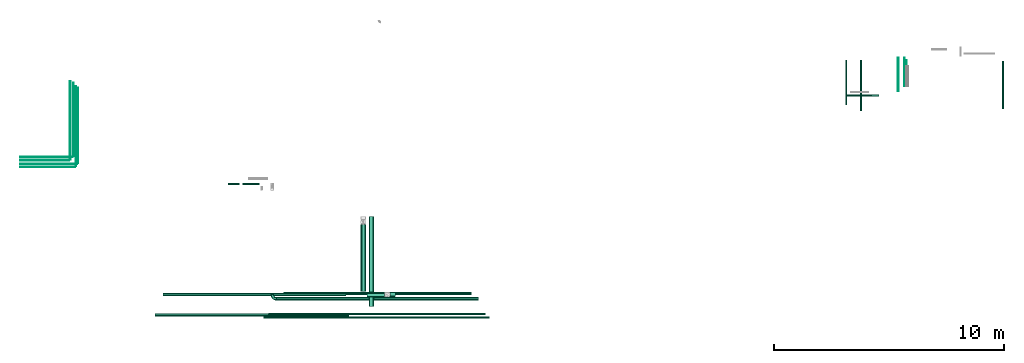
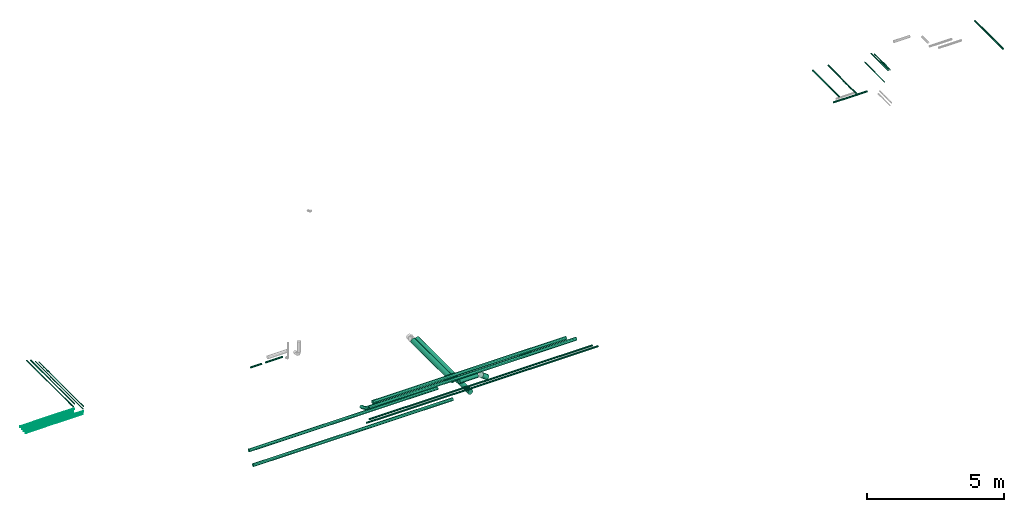
# One storey, part 1 of 6: 27 flow segments, 1 flow fitting.
"""IFC2X3 building model written with IfcOpenShell, lengths in millimetres."""

import ifcopenshell
import ifcopenshell.guid

model = None  # the IFC model being written
_history = None  # IfcOwnerHistory: only IFC2X3 demands one
_inside = {}  # id of a spatial element -> (the spatial element, [elements in it])
_under = {}  # id of a project, library or spatial element -> (it, [spatial elements below it])
_declared = {}  # id of a project -> (the project, [libraries it declares])
_typed = {}  # id of a type object -> (the type object, [elements of that type])
_made_of = {}  # id of a material, layer set ... -> (it, [elements and type objects made of it])


def new_model(schema):
    """Start an empty IFC model of exactly this schema.

    Asked for "IFC4X3", IfcOpenShell would pick the latest addendum, in which some entities
    have other attributes; the version numbers below select the first issue.
    IFC2X3 requires an IfcOwnerHistory on every rooted entity: one is made here for all.
    """
    global model, _history
    if schema == "IFC4X3":
        model = ifcopenshell.file(schema_version=(4, 3, 0, 0))
    else:
        model = ifcopenshell.file(schema=schema)
    _inside.clear()
    _under.clear()
    _declared.clear()
    _typed.clear()
    _made_of.clear()
    _history = None
    if model.schema == "IFC2X3":
        org = make("IfcOrganization", Name="unknown")
        user = make(
            "IfcPersonAndOrganization",
            ThePerson=make("IfcPerson", FamilyName="unknown"),
            TheOrganization=org,
        )
        app = make(
            "IfcApplication",
            ApplicationDeveloper=org,
            Version="unknown",
            ApplicationFullName="unknown",
            ApplicationIdentifier="unknown",
        )
        _history = make(
            "IfcOwnerHistory",
            OwningUser=user,
            OwningApplication=app,
            ChangeAction="ADDED",
            CreationDate=0,
        )
    return model


def make(cls, **values):
    """One entity of the class cls with the attributes given. An attribute that is None is left unset."""
    return model.create_entity(
        cls, **{name: value for name, value in values.items() if value is not None}
    )


def entity(cls, *values):
    """Any entity or typed value of the class cls, its attributes in the order of the schema. None: left unset."""
    e = model.create_entity(cls)
    for i, value in enumerate(values):
        if value is not None:
            e[i] = value
    return e


def rooted(cls, **values):
    """An entity with a GlobalId (a new one), such as an element, a storey or a relation."""
    return make(cls, GlobalId=ifcopenshell.guid.new(), OwnerHistory=_history, **values)


def si_unit(unit_type, name, prefix=None):
    """IfcSIUnit, for example si_unit("LENGTHUNIT", "METRE", prefix="MILLI")."""
    return make("IfcSIUnit", UnitType=unit_type, Prefix=prefix, Name=name)


def converted_unit(unit_type, name, factor, base, dimensions=None, offset=None):
    """IfcConversionBasedUnit, such as the inch: factor (a typed value) times the base unit."""
    return make(
        "IfcConversionBasedUnit"
        if offset is None
        else "IfcConversionBasedUnitWithOffset",
        ConversionOffset=offset,
        Dimensions=None
        if dimensions is None
        else entity("IfcDimensionalExponents", *dimensions),
        UnitType=unit_type,
        Name=name,
        ConversionFactor=make(
            "IfcMeasureWithUnit", ValueComponent=factor, UnitComponent=base
        ),
    )


def derived_unit(unit_type, elements):
    """IfcDerivedUnit: a product of units, each with its exponent."""
    return make(
        "IfcDerivedUnit",
        Elements=[
            make("IfcDerivedUnitElement", Unit=unit, Exponent=power)
            for unit, power in elements
        ],
        UnitType=unit_type,
    )


def assignment(units):
    """IfcUnitAssignment: the units of a project."""
    return None if units is None else make("IfcUnitAssignment", Units=units)


def point(xyz):
    """IfcCartesianPoint."""
    return None if xyz is None else make("IfcCartesianPoint", Coordinates=xyz)


def direction(xyz):
    """IfcDirection."""
    return None if xyz is None else make("IfcDirection", DirectionRatios=xyz)


def frame(location, z_axis=None, x_axis=None):
    """IfcAxis2Placement3D, a coordinate frame: its origin and axes. An axis left out is left unset."""
    return make(
        "IfcAxis2Placement3D",
        Location=point(location),
        Axis=direction(z_axis),
        RefDirection=direction(x_axis),
    )


def frame_2d(location, x_axis=None):
    """IfcAxis2Placement2D, a coordinate frame in the plane: its origin and x axis."""
    return make(
        "IfcAxis2Placement2D", Location=point(location), RefDirection=direction(x_axis)
    )


def origin():
    """The frame at (0, 0, 0) with its axes left unset."""
    return frame((0.0, 0.0, 0.0))


def origin_2d_with_axis():
    """The frame at (0, 0) in the plane with the x axis (1, 0) written out."""
    return frame_2d((0.0, 0.0), x_axis=(1.0, 0.0))


def place(relative_to, where):
    """IfcLocalPlacement: puts the frame where relative to a parent placement (None: the world)."""
    return make(
        "IfcLocalPlacement", PlacementRelTo=relative_to, RelativePlacement=where
    )


def context(
    kind, dimensions, precision=None, world=None, true_north=None, identifier=None
):
    """IfcGeometricRepresentationContext, for example the 3D "Model" context."""
    return make(
        "IfcGeometricRepresentationContext",
        ContextIdentifier=identifier,
        ContextType=kind,
        CoordinateSpaceDimension=dimensions,
        Precision=precision,
        WorldCoordinateSystem=world,
        TrueNorth=true_north,
    )


def subcontext(parent, identifier, kind, view, scale=None):
    """IfcGeometricRepresentationSubContext, for example "Body" below "Model"."""
    return make(
        "IfcGeometricRepresentationSubContext",
        ContextIdentifier=identifier,
        ContextType=kind,
        ParentContext=parent,
        TargetScale=scale,
        TargetView=view,
    )


def project(units=None, contexts=None):
    """IfcProject with its units and contexts."""
    return rooted(
        "IfcProject",
        Name="project",
        RepresentationContexts=contexts,
        UnitsInContext=assignment(units),
    )


def spatial(cls, under=None, at=None, **own):
    """A site, building, storey or space (cls), placed at a placement, below another one or the project."""
    s = rooted(cls, ObjectPlacement=at, **own)
    if under is not None:
        _under.setdefault(under.id(), (under, []))[1].append(s)
    return s


def profile(cls, at=None, kind="AREA", **sizes):
    """A parametric profile (cls). Its sizes go by their IFC names, for example OverallWidth=200.0."""
    return make(cls, ProfileType=kind, Position=at, **sizes)


def circle(**sizes):
    """IfcCircleProfileDef."""
    return profile("IfcCircleProfileDef", **sizes)


def extrude(swept, where, along, depth):
    """IfcExtrudedAreaSolid: the profile swept, set in the frame where, extruded along a direction by depth."""
    return make(
        "IfcExtrudedAreaSolid",
        SweptArea=swept,
        Position=where,
        ExtrudedDirection=direction(along),
        Depth=depth,
    )


def faces_of(points, faces, orient=None, outer=None):
    """IfcFace entities. A face is a list of loops; a loop is a list of indices into points, from 0.

    orient and outer hold one flag for each loop. By default every Orientation is true, the
    first loop of a face is its IfcFaceOuterBound and the others are IfcFaceBound.
    """
    made = []
    for i, loops in enumerate(faces):
        bounds = []
        for j, loop in enumerate(loops):
            is_outer = j == 0 if outer is None else outer[i][j]
            bounds.append(
                make(
                    "IfcFaceOuterBound" if is_outer else "IfcFaceBound",
                    Bound=make("IfcPolyLoop", Polygon=[points[k] for k in loop]),
                    Orientation=True if orient is None else orient[i][j],
                )
            )
        made.append(make("IfcFace", Bounds=bounds))
    return made


def faceted_brep(points, faces, orient=None, outer=None, voids=None):
    """IfcFacetedBrep: a solid bounded by flat faces; with voids (closed shells), ...WithVoids."""
    shared = [point(p) for p in points]
    hull = make("IfcClosedShell", CfsFaces=faces_of(shared, faces, orient, outer))
    if voids is None:
        return make("IfcFacetedBrep", Outer=hull)
    return make(
        "IfcFacetedBrepWithVoids",
        Outer=hull,
        Voids=[
            make(cls, CfsFaces=faces_of(shared, fs, o, b)) for cls, fs, o, b in voids
        ],
    )


def shape(context_of_items, identifier, shape_type, items):
    """IfcShapeRepresentation: the items that make up one representation, for example the "Body"."""
    return make(
        "IfcShapeRepresentation",
        ContextOfItems=context_of_items,
        RepresentationIdentifier=identifier,
        RepresentationType=shape_type,
        Items=items,
    )


def source(mapping_origin, context_of_items, identifier, shape_type, items):
    """IfcRepresentationMap: a shape defined once, which mapped items show again and again."""
    return make(
        "IfcRepresentationMap",
        MappingOrigin=mapping_origin,
        MappedRepresentation=shape(context_of_items, identifier, shape_type, items),
    )


def transform(
    local_origin,
    x_axis=None,
    y_axis=None,
    z_axis=None,
    scale=None,
    scale2=None,
    scale3=None,
    uniform=True,
):
    """IfcCartesianTransformationOperator3D, or its non-uniform kind. x_axis, y_axis, z_axis: its Axis1, 2, 3."""
    if uniform:
        return make(
            "IfcCartesianTransformationOperator3D",
            Axis1=direction(x_axis),
            Axis2=direction(y_axis),
            LocalOrigin=point(local_origin),
            Scale=scale,
            Axis3=direction(z_axis),
        )
    return make(
        "IfcCartesianTransformationOperator3DnonUniform",
        Axis1=direction(x_axis),
        Axis2=direction(y_axis),
        LocalOrigin=point(local_origin),
        Scale=scale,
        Axis3=direction(z_axis),
        Scale2=scale2,
        Scale3=scale3,
    )


def mapped(mapping_source, mapping_target):
    """IfcMappedItem: shows the shape of a source again, moved by a transform."""
    return make(
        "IfcMappedItem", MappingSource=mapping_source, MappingTarget=mapping_target
    )


def material(Name=None, Category=None):
    """IfcMaterial."""
    return make("IfcMaterial", Name=Name, Category=Category)


def made_of(thing, what):
    """Note that an element or type object is made of a material, layer set ...; save() writes the relation."""
    if what is not None:
        _made_of.setdefault(what.id(), (what, []))[1].append(thing)
    return thing


def type_object(cls, material=None, **own):
    """A type object (cls), such as IfcWallType, which elements share."""
    return made_of(rooted(cls, **own), material)


def type_shapes(of_type, sources):
    """Give a type object the sources (RepresentationMaps) that its elements show as mapped items."""
    of_type.RepresentationMaps = sources


def element(
    cls,
    number,
    at=None,
    inside=None,
    cuts=None,
    type_object=None,
    material=None,
    context=None,
    identifier="Body",
    shape_type=None,
    held_by="IfcProductDefinitionShape",
    body=None,
    shapes=None,
    **own,
):
    """One element of the class cls, such as IfcWall. Its Tag is "e" and its number.

    at: its placement. inside: the storey or other place that contains it. cuts: it is an
    opening in that element (IfcRelVoidsElement). A single representation is given by context,
    identifier, shape_type and body (its items); several are given by shapes. held_by: the class
    of the entity that holds the representations. save() writes the other relations.
    """
    e = rooted(cls, Tag="e%d" % number, ObjectPlacement=at, **own)
    if body is not None:
        shapes = [shape(context, identifier, shape_type, body)]
    if shapes is not None:
        e.Representation = make(held_by, Representations=shapes)
    if inside is not None:
        _inside.setdefault(inside.id(), (inside, []))[1].append(e)
    if cuts is not None:
        rooted(
            "IfcRelVoidsElement", RelatingBuildingElement=cuts, RelatedOpeningElement=e
        )
    if type_object is not None:
        _typed.setdefault(type_object.id(), (type_object, []))[1].append(e)
    return made_of(e, material)


def aggregate(whole, parts):
    """IfcRelAggregates: a whole, such as a stair, and the parts it consists of."""
    return rooted("IfcRelAggregates", RelatingObject=whole, RelatedObjects=parts)


def save(model, path):
    """Write the relations noted so far, then the file.

    IfcRelAggregates (storeys below a building ...), IfcRelContainedInSpatialStructure (elements
    in a storey), IfcRelDefinesByType, IfcRelAssociatesMaterial and IfcRelDeclares: one each for
    every whole, place, type object, material and project.
    """
    for whole, parts in _under.values():
        aggregate(whole, parts)
    for where, things in _inside.values():
        rooted(
            "IfcRelContainedInSpatialStructure",
            RelatedElements=things,
            RelatingStructure=where,
        )
    for kind, things in _typed.values():
        rooted("IfcRelDefinesByType", RelatedObjects=things, RelatingType=kind)
    for what, things in _made_of.values():
        rooted("IfcRelAssociatesMaterial", RelatedObjects=things, RelatingMaterial=what)
    for by, libraries in _declared.values():
        rooted("IfcRelDeclares", RelatingContext=by, RelatedDefinitions=libraries)
    model.write(path)


model = new_model("IFC2X3")

# Units and contexts
model_context = context("Model", 3, precision=0.01, world=origin(), true_north=direction((6.12303176911189e-17, 1.0)))
body_context = subcontext(model_context, "Body", "Model", "MODEL_VIEW")
ifc_project = project(units=[si_unit("LENGTHUNIT", "METRE", prefix="MILLI"), si_unit("AREAUNIT", "SQUARE_METRE"), si_unit("VOLUMEUNIT", "CUBIC_METRE"), converted_unit("PLANEANGLEUNIT", "DEGREE", entity("IfcRatioMeasure", 0.0174532925199433), si_unit("PLANEANGLEUNIT", "RADIAN"), dimensions=[0, 0, 0, 0, 0, 0, 0]), si_unit("MASSUNIT", "GRAM", prefix="KILO"), derived_unit("MASSDENSITYUNIT", [(si_unit("MASSUNIT", "GRAM", prefix="KILO"), 1), (si_unit("LENGTHUNIT", "METRE"), -3)]), derived_unit("MOMENTOFINERTIAUNIT", [(si_unit("LENGTHUNIT", "METRE"), 4)]), si_unit("TIMEUNIT", "SECOND"), si_unit("FREQUENCYUNIT", "HERTZ"), si_unit("THERMODYNAMICTEMPERATUREUNIT", "DEGREE_CELSIUS"), derived_unit("THERMALTRANSMITTANCEUNIT", [(si_unit("MASSUNIT", "GRAM", prefix="KILO"), 1), (si_unit("THERMODYNAMICTEMPERATUREUNIT", "KELVIN"), -1), (si_unit("TIMEUNIT", "SECOND"), -3)]), derived_unit("VOLUMETRICFLOWRATEUNIT", [(si_unit("LENGTHUNIT", "METRE"), 3), (si_unit("TIMEUNIT", "SECOND"), -1)]), derived_unit("MASSFLOWRATEUNIT", [(si_unit("MASSUNIT", "GRAM", prefix="KILO"), 1), (si_unit("TIMEUNIT", "SECOND"), -1)]), derived_unit("ROTATIONALFREQUENCYUNIT", [(si_unit("TIMEUNIT", "SECOND"), -1)]), si_unit("ELECTRICCURRENTUNIT", "AMPERE"), si_unit("ELECTRICVOLTAGEUNIT", "VOLT"), si_unit("POWERUNIT", "WATT"), si_unit("FORCEUNIT", "NEWTON", prefix="KILO"), si_unit("ILLUMINANCEUNIT", "LUX"), si_unit("LUMINOUSFLUXUNIT", "LUMEN"), si_unit("LUMINOUSINTENSITYUNIT", "CANDELA"), derived_unit("USERDEFINED", [(si_unit("MASSUNIT", "GRAM", prefix="KILO"), -1), (si_unit("LENGTHUNIT", "METRE"), -2), (si_unit("TIMEUNIT", "SECOND"), 3), (si_unit("LUMINOUSFLUXUNIT", "LUMEN"), 1)]), derived_unit("LINEARVELOCITYUNIT", [(si_unit("LENGTHUNIT", "METRE"), 1), (si_unit("TIMEUNIT", "SECOND"), -1)]), si_unit("PRESSUREUNIT", "PASCAL"), derived_unit("USERDEFINED", [(si_unit("LENGTHUNIT", "METRE"), -2), (si_unit("MASSUNIT", "GRAM", prefix="KILO"), 1), (si_unit("TIMEUNIT", "SECOND"), -2)]), derived_unit("LINEARFORCEUNIT", [(si_unit("MASSUNIT", "GRAM", prefix="KILO"), 1), (si_unit("LENGTHUNIT", "METRE"), 1), (si_unit("TIMEUNIT", "SECOND"), -2), (si_unit("LENGTHUNIT", "METRE"), -1)]), derived_unit("PLANARFORCEUNIT", [(si_unit("MASSUNIT", "GRAM", prefix="KILO"), 1), (si_unit("LENGTHUNIT", "METRE"), 1), (si_unit("TIMEUNIT", "SECOND"), -2), (si_unit("LENGTHUNIT", "METRE"), -2)])], contexts=[model_context])

# Site, building, storey
site_placement = place(None, origin())
site = spatial("IfcSite", under=ifc_project, at=site_placement, CompositionType="ELEMENT")
building_placement = place(site_placement, origin())
building = spatial("IfcBuilding", under=site, at=building_placement, CompositionType="ELEMENT")
storey_placement = place(building_placement, origin())
storey = spatial("IfcBuildingStorey", under=building, at=storey_placement, Name="01", CompositionType="ELEMENT", Elevation=0.0)

# Flow segments
pipe_segment_type_1 = type_object("IfcPipeSegmentType", PredefinedType="NOTDEFINED")
flow_segment_1_placement = place(storey_placement, frame((26962.64, 6377.22, 31260.65)))
element("IfcFlowSegment", 1, at=flow_segment_1_placement, inside=storey, type_object=pipe_segment_type_1, context=body_context, shape_type="SweptSolid", body=[
    extrude(circle(Radius=37.75, at=origin_2d_with_axis()), frame((0.0, 39.35, 39.35), z_axis=(1.0, 0.0, 0.0), x_axis=(0.0, 1.0, 0.0)), (0.0, 0.0, 1.0), 9430.07864615945),
])
flow_segment_2_placement = place(storey_placement, frame((26758.64, 6226.36, 31260.65)))
element("IfcFlowSegment", 2, at=flow_segment_2_placement, inside=storey, type_object=pipe_segment_type_1, context=body_context, shape_type="SweptSolid", body=[
    extrude(circle(Radius=37.75, at=origin_2d_with_axis()), frame((0.0, 39.35, 39.35), z_axis=(1.0, 0.0, 0.0), x_axis=(0.0, 1.0, 0.0)), (0.0, 0.0, 1.0), 9795.00564256815),
])
flow_segment_3_placement = place(storey_placement, frame((31318.9, 6749.26, 30638.9)))
element("IfcFlowSegment", 3, at=flow_segment_3_placement, inside=storey, type_object=pipe_segment_type_1, context=body_context, shape_type="SweptSolid", body=[
    extrude(circle(Radius=109.5, at=origin_2d_with_axis()), frame((111.1, 0.0, 111.1), z_axis=(0.0, 1.0, 0.0), x_axis=(1.0, 0.0, 0.0)), (0.0, 0.0, 1.0), 3900.73593128801),
])
flow_segment_4_placement = place(storey_placement, frame((30968.9, 7406.2, 30888.9)))
element("IfcFlowSegment", 4, at=flow_segment_4_placement, inside=storey, type_object=pipe_segment_type_1, context=body_context, shape_type="SweptSolid", body=[
    extrude(circle(Radius=109.5, at=origin_2d_with_axis()), frame((111.1, 0.0, 111.1), z_axis=(0.0, 1.0, 0.0), x_axis=(-1.0, 0.0, 0.0)), (0.0, 0.0, 1.0), 2913.62254577972),
])
flow_segment_5_placement = place(storey_placement, frame((22025.11, 6306.9, 30931.9)))
element("IfcFlowSegment", 5, at=flow_segment_5_placement, inside=storey, type_object=pipe_segment_type_1, context=body_context, shape_type="SweptSolid", body=[
    extrude(circle(Radius=66.5, at=origin_2d_with_axis()), frame((0.0, 68.1, 68.1), z_axis=(1.0, 0.0, 0.0), x_axis=(0.0, 1.0, 0.0)), (0.0, 0.0, 1.0), 8444.99999999997),
])
flow_segment_6_placement = place(storey_placement, frame((22364.76, 7198.11, 30931.91)))
element("IfcFlowSegment", 6, at=flow_segment_6_placement, inside=storey, type_object=pipe_segment_type_1, context=body_context, shape_type="SweptSolid", body=[
    extrude(circle(Radius=66.5, at=origin_2d_with_axis()), frame((0.0, 68.1, 68.1), z_axis=(1.0, 0.0, 0.0), x_axis=(0.0, 1.0, 0.0)), (0.0, 0.0, 1.0), 7974.99960693679),
])
flow_segment_7_placement = place(storey_placement, frame((31240.0, 7155.11, 30888.9)))
element("IfcFlowSegment", 7, at=flow_segment_7_placement, inside=storey, type_object=pipe_segment_type_1, context=body_context, shape_type="SweptSolid", body=[
    extrude(circle(Radius=109.5, at=origin_2d_with_axis()), frame((0.0, 111.1, 111.1), z_axis=(1.0, 0.0, 0.0), x_axis=(0.0, -1.0, 0.0)), (0.0, 0.0, 1.0), 768.43288548493),
])
flow_segment_8_placement = place(storey_placement, frame((32122.56, 7155.11, 30673.09)))
element("IfcFlowSegment", 8, at=flow_segment_8_placement, inside=storey, type_object=pipe_segment_type_1, context=body_context, shape_type="SweptSolid", body=[
    extrude(circle(Radius=109.5, at=origin_2d_with_axis()), frame((299.07, 111.1, 88.57), z_axis=(-0.794332086218686, 0.0, 0.60748377493022), x_axis=(0.0, 1.0, 0.0)), (0.0, 0.0, 1.0), 290.756106971443),
])
pipe_segment_type_2 = type_object("IfcPipeSegmentType", PredefinedType="NOTDEFINED")
flow_segment_9_placement = place(storey_placement, frame((52063.1, 15883.03, 30860.65)))
element("IfcFlowSegment", 9, at=flow_segment_9_placement, inside=storey, type_object=pipe_segment_type_2, context=body_context, shape_type="SweptSolid", body=[
    extrude(circle(Radius=37.75, at=origin_2d_with_axis()), frame((0.0, 39.35, 39.35), z_axis=(1.0, 0.0, 0.0), x_axis=(0.0, 1.0, 0.0)), (0.0, 0.0, 1.0), 1432.30500000002),
])
flow_segment_10_placement = place(storey_placement, frame((16166.05, 13231.65, 30581.65)))
element("IfcFlowSegment", 10, at=flow_segment_10_placement, inside=storey, type_object=pipe_segment_type_2, context=body_context, shape_type="SweptSolid", body=[
    extrude(circle(Radius=16.75, at=origin_2d_with_axis()), frame((0.0, 18.35, 18.35), z_axis=(1.0, 0.0, 0.0), x_axis=(0.0, -1.0, 0.0)), (0.0, 0.0, 1.0), 2276.50487666268),
])
flow_segment_11_placement = place(storey_placement, frame((16166.05, 13081.65, 30581.27)))
element("IfcFlowSegment", 11, at=flow_segment_11_placement, inside=storey, type_object=pipe_segment_type_2, context=body_context, shape_type="SweptSolid", body=[
    extrude(circle(Radius=16.75, at=origin_2d_with_axis()), frame((2141.49, 18.35, 18.35), z_axis=(-0.999999984094241, 0.0, 0.000178357837292143), x_axis=(0.0, -1.0, 0.0)), (0.0, 0.0, 1.0), 2141.49184794512),
])
flow_segment_12_placement = place(storey_placement, frame((16157.15, 12935.0, 30585.0)))
element("IfcFlowSegment", 12, at=flow_segment_12_placement, inside=storey, type_object=pipe_segment_type_2, context=body_context, shape_type="SweptSolid", body=[
    extrude(circle(Radius=13.4, at=origin_2d_with_axis()), frame((0.0, 15.0, 15.0), z_axis=(1.0, 0.0, 0.0), x_axis=(0.0, -1.0, 0.0)), (0.0, 0.0, 1.0), 2496.80000000001),
])
flow_segment_13_placement = place(storey_placement, frame((16157.15, 12805.0, 30585.0)))
element("IfcFlowSegment", 13, at=flow_segment_13_placement, inside=storey, type_object=pipe_segment_type_2, context=body_context, shape_type="SweptSolid", body=[
    extrude(circle(Radius=13.4, at=origin_2d_with_axis()), frame((0.0, 15.0, 15.0), z_axis=(1.0, 0.0, 0.0), x_axis=(0.0, -1.0, 0.0)), (0.0, 0.0, 1.0), 2399.29864410693),
])
flow_segment_14_placement = place(storey_placement, frame((58858.57, 15341.2, 31210.65)))
element("IfcFlowSegment", 14, at=flow_segment_14_placement, inside=storey, type_object=pipe_segment_type_2, context=body_context, shape_type="SweptSolid", body=[
    extrude(circle(Radius=37.75, at=origin_2d_with_axis()), frame((39.35, 0.0, 39.35), z_axis=(0.0, 1.0, 0.0), x_axis=(-1.0, 0.0, 0.0)), (0.0, 0.0, 1.0), 2063.795886356),
])
flow_segment_15_placement = place(storey_placement, frame((18668.06, 12979.1, 30785.0)))
element("IfcFlowSegment", 15, at=flow_segment_15_placement, inside=storey, type_object=pipe_segment_type_2, context=body_context, shape_type="SweptSolid", body=[
    extrude(circle(Radius=13.4, at=origin_2d_with_axis()), frame((15.0, 0.0, 15.0), z_axis=(0.0, 1.0, 0.0), x_axis=(1.0, 0.0, 0.0)), (0.0, 0.0, 1.0), 3268.37566003858),
])
flow_segment_16_placement = place(storey_placement, frame((54673.84, 16326.56, 31181.65)))
element("IfcFlowSegment", 16, at=flow_segment_16_placement, inside=storey, type_object=pipe_segment_type_2, context=body_context, shape_type="SweptSolid", body=[
    extrude(circle(Radius=16.75, at=origin_2d_with_axis()), frame((18.35, 0.0, 18.35), z_axis=(0.0, 1.0, 0.0), x_axis=(-1.0, 0.0, 0.0)), (0.0, 0.0, 1.0), 1135.43813554226),
])
flow_segment_17_placement = place(storey_placement, frame((54593.84, 16326.56, 31181.65)))
element("IfcFlowSegment", 17, at=flow_segment_17_placement, inside=storey, type_object=pipe_segment_type_2, context=body_context, shape_type="SweptSolid", body=[
    extrude(circle(Radius=16.75, at=origin_2d_with_axis()), frame((18.35, 0.0, 18.35), z_axis=(0.0, 1.0, 0.0), x_axis=(-1.0, 0.0, 0.0)), (0.0, 0.0, 1.0), 1234.25889000002),
])
flow_segment_18_placement = place(storey_placement, frame((52695.46, 15266.32, 31374.4)))
element("IfcFlowSegment", 18, at=flow_segment_18_placement, inside=storey, type_object=pipe_segment_type_2, context=body_context, shape_type="SweptSolid", body=[
    extrude(circle(Radius=24.0, at=origin_2d_with_axis()), frame((25.6, 0.0, 25.6), z_axis=(0.0, 1.0, 0.0), x_axis=(1.0, 0.0, 0.0)), (0.0, 0.0, 1.0), 2176.68411146079),
])
flow_segment_19_placement = place(storey_placement, frame((18570.56, 12849.1, 30785.0)))
element("IfcFlowSegment", 19, at=flow_segment_19_placement, inside=storey, type_object=pipe_segment_type_2, context=body_context, shape_type="SweptSolid", body=[
    extrude(circle(Radius=13.4, at=origin_2d_with_axis()), frame((15.0, 0.0, 15.0), z_axis=(0.0, 1.0, 0.0), x_axis=(1.0, 0.0, 0.0)), (0.0, 0.0, 1.0), 3476.70838132023),
])
flow_segment_20_placement = place(storey_placement, frame((18462.21, 13288.0, 30781.65)))
element("IfcFlowSegment", 20, at=flow_segment_20_placement, inside=storey, type_object=pipe_segment_type_2, context=body_context, shape_type="SweptSolid", body=[
    extrude(circle(Radius=16.75, at=origin_2d_with_axis()), frame((18.35, 0.0, 18.35), z_axis=(0.0, 1.0, 0.0), x_axis=(1.0, 0.0, 0.0)), (0.0, 0.0, 1.0), 3191.91504634766),
])
flow_segment_21_placement = place(storey_placement, frame((18327.21, 13138.0, 30781.65)))
element("IfcFlowSegment", 21, at=flow_segment_21_placement, inside=storey, type_object=pipe_segment_type_2, context=body_context, shape_type="SweptSolid", body=[
    extrude(circle(Radius=16.75, at=origin_2d_with_axis()), frame((18.35, 0.0, 18.35), z_axis=(0.0, 1.0, 0.0), x_axis=(1.0, 0.0, 0.0)), (0.0, 0.0, 1.0), 3410.60077364376),
])
flow_segment_22_placement = place(storey_placement, frame((52048.79, 15521.32, 31374.4)))
element("IfcFlowSegment", 22, at=flow_segment_22_placement, inside=storey, type_object=pipe_segment_type_2, context=body_context, shape_type="SweptSolid", body=[
    extrude(circle(Radius=24.0, at=origin_2d_with_axis()), frame((25.6, 0.0, 25.6), z_axis=(0.0, 1.0, 0.0), x_axis=(1.0, 0.0, 0.0)), (0.0, 0.0, 1.0), 1921.68411146078),
])
flow_segment_23_placement = place(storey_placement, frame((54324.79, 16112.38, 30885.04)))
element("IfcFlowSegment", 23, at=flow_segment_23_placement, inside=storey, type_object=pipe_segment_type_2, context=body_context, shape_type="SweptSolid", body=[
    extrude(circle(Radius=13.4, at=origin_2d_with_axis()), frame((15.0, 0.0, 15.0), z_axis=(0.0, 1.0, 0.0), x_axis=(1.0, 0.0, 0.0)), (0.0, 0.0, 1.0), 1450.89994899431),
])
flow_segment_24_placement = place(storey_placement, frame((27310.33, 7008.4, 31228.4)))
element("IfcFlowSegment", 24, at=flow_segment_24_placement, inside=storey, type_object=pipe_segment_type_2, context=body_context, shape_type="SweptSolid", body=[
    extrude(circle(Radius=70.0, at=origin_2d_with_axis()), frame((0.0, 71.6, 71.6), z_axis=(1.0, 0.0, 0.0), x_axis=(0.0, 1.0, 0.0)), (0.0, 0.0, 1.0), 8785.70070250989),
])
flow_segment_25_placement = place(storey_placement, frame((27610.03, 7238.4, 31228.4)))
element("IfcFlowSegment", 25, at=flow_segment_25_placement, inside=storey, type_object=pipe_segment_type_2, context=body_context, shape_type="SweptSolid", body=[
    extrude(circle(Radius=70.0, at=origin_2d_with_axis()), frame((0.0, 71.6, 71.6), z_axis=(1.0, 0.0, 0.0), x_axis=(0.0, 1.0, 0.0)), (0.0, 0.0, 1.0), 8185.03374931238),
])
flow_segment_26_placement = place(storey_placement, frame((25208.72, 12030.66, 30760.65)))
element("IfcFlowSegment", 26, at=flow_segment_26_placement, inside=storey, type_object=pipe_segment_type_2, context=body_context, shape_type="SweptSolid", body=[
    extrude(circle(Radius=37.75, at=origin_2d_with_axis()), frame((0.0, 39.35, 39.35), z_axis=(1.0, 0.0, 0.0), x_axis=(0.0, 1.0, 0.0)), (0.0, 0.0, 1.0), 481.487460675076),
])
flow_segment_27_placement = place(storey_placement, frame((25842.21, 12030.66, 30760.65)))
element("IfcFlowSegment", 27, at=flow_segment_27_placement, inside=storey, type_object=pipe_segment_type_2, context=body_context, shape_type="SweptSolid", body=[
    extrude(circle(Radius=37.75, at=origin_2d_with_axis()), frame((0.0, 39.35, 39.35), z_axis=(1.0, 0.0, 0.0), x_axis=(0.0, 1.0, 0.0)), (0.0, 0.0, 1.0), 726.427640378603),
])

# Flow fitting
ifc_material = material()
pipe_fitting_type = type_object("IfcPipeFittingType", Name="ADSK_1", PredefinedType="NOTDEFINED", material=ifc_material)
shared_shape = source(origin(), body_context, "Body", "Brep", [
    faceted_brep([(-190.0, 18.08, -67.47), (-190.0, 0.0, -69.85), (-190.0, -18.08, -67.47), (-190.0, -34.93, -60.49), (-190.0, -49.39, -49.39), (-190.0, -60.49, -34.93), (-190.0, -67.47, -18.08), (-190.0, -69.85, 0.0), (-190.0, -67.47, 18.08), (-190.0, -60.49, 34.92), (-190.0, -49.39, 49.39), (-190.0, -34.93, 60.49), (-190.0, -18.08, 67.47), (-190.0, 0.0, 69.85), (-190.0, 18.08, 67.47), (-190.0, 34.92, 60.49), (-190.0, 49.39, 49.39), (-190.0, 60.49, 34.92), (-190.0, 67.47, 18.08), (-190.0, 69.85, 0.0), (-190.0, 67.47, -18.08), (-190.0, 60.49, -34.93), (-190.0, 49.39, -49.39), (-190.0, 34.92, -60.49), (18.08, 190.0, -67.47), (0.0, 190.0, -69.85), (-18.08, 190.0, -67.47), (-34.92, 190.0, -60.49), (-49.39, 190.0, -49.39), (-60.49, 190.0, -34.93), (-67.47, 190.0, -18.08), (-69.85, 190.0, 0.0), (-67.47, 190.0, 18.08), (-60.49, 190.0, 34.92), (-49.39, 190.0, 49.39), (-34.92, 190.0, 60.49), (-18.08, 190.0, 67.47), (0.0, 190.0, 69.85), (18.08, 190.0, 67.47), (34.93, 190.0, 60.49), (49.39, 190.0, 49.39), (60.49, 190.0, 34.92), (67.47, 190.0, 18.08), (69.85, 190.0, 0.0), (67.47, 190.0, -18.08), (60.49, 190.0, -34.93), (49.39, 190.0, -49.39), (34.93, 190.0, -60.49), (-29.62, 146.98, 65.62), (-13.75, 135.37, 69.64), (-124.22, -36.33, 52.83), (-140.23, -52.18, 40.04), (-80.56, -34.09, 36.78), (-140.97, -24.01, 63.29), (-80.93, -8.05, 59.8), (-100.59, 5.62, 68.24), (-125.19, -57.65, 22.9), (-139.31, -64.86, 0.0), (-28.7, -8.91, 22.6), (-45.64, -26.06, 0.0), (-6.26, 6.26, 0.0), (-105.44, 36.89, 68.2), (-118.83, 43.56, 64.34), (-146.98, 29.62, 65.62), (-71.47, -38.86, 17.07), (-90.56, -50.07, 0.0), (-0.6, 27.02, 35.97), (-44.76, -2.31, 47.74), (-42.86, -12.1, 35.78), (-148.03, -7.38, 68.85), (-135.37, 13.75, 69.64), (-67.48, 159.11, 28.79), (36.32, 124.15, 52.82), (-38.8, 102.11, 68.2), (-24.59, 96.61, 69.85), (-81.73, 130.22, 21.92), (-65.15, 30.31, 68.68), (-27.72, 54.52, 66.49), (-44.98, 61.25, 69.74), (-75.73, 152.87, 0.0), (-159.11, 67.48, 28.79), (-130.22, 81.73, 21.92), (-152.87, 75.73, 0.0), (-76.65, 126.59, 35.57), (-101.51, 101.51, 25.92), (-96.74, 96.74, 38.75), (-144.94, 60.97, 45.11), (-159.57, 43.91, 56.71), (-119.38, 92.8, 0.0), (50.07, 90.56, 0.0), (57.42, 124.25, 22.84), (38.8, 71.6, 17.49), (64.86, 139.31, 0.0), (52.17, 140.21, 40.03), (33.37, 79.39, 36.99), (24.0, 140.95, 63.29), (8.03, 80.92, 59.81), (-82.61, -22.17, 50.94), (7.38, 148.03, 68.85), (-100.26, 79.14, 51.33), (-75.76, 96.1, 55.72), (-76.12, 111.95, 46.7), (-92.8, 119.38, 0.0), (-104.27, 104.27, 12.31), (10.07, 27.17, 16.15), (26.06, 45.64, 0.0), (-61.21, 144.14, 45.16), (-44.13, 158.15, 56.77), (-55.26, 120.41, 58.38), (9.95, 57.03, 48.64), (29.48, 90.08, 47.56), (-5.62, 100.59, 68.24), (-122.78, 54.24, 58.28), (-86.25, 73.26, 61.12), (-95.79, 24.47, 69.85), (-126.59, 76.65, 35.57), (-17.15, 26.56, 50.85), (-29.82, 29.82, 59.54), (-70.73, 11.02, 65.19), (-58.6, 94.58, 64.16), (-71.14, 66.1, 67.41), (-158.15, 44.13, -56.77), (33.37, 79.39, -36.99), (10.07, 27.17, -16.15), (-0.6, 27.02, -35.97), (-100.59, 5.62, -68.24), (-148.03, -7.38, -68.85), (-135.37, 13.75, -69.64), (-130.22, 81.73, -21.92), (-146.98, 29.62, -65.62), (-102.11, 38.8, -68.2), (-96.61, 24.59, -69.85), (-83.02, -24.86, -48.76), (-44.76, -2.31, -47.74), (-80.56, -34.09, -36.78), (-122.68, -57.24, -22.15), (-71.43, -38.87, -16.95), (-104.27, 104.27, -12.31), (-159.11, 67.48, -28.79), (-144.14, 61.21, -45.16), (7.38, 148.03, -68.85), (-13.75, 135.37, -69.64), (-79.14, 100.26, -51.33), (-96.1, 75.76, -55.72), (-111.95, 76.12, -46.7), (-80.93, -8.05, -59.8), (-124.22, -36.33, -52.83), (-140.23, -52.18, -40.04), (-24.47, 95.79, -69.85), (-36.89, 105.44, -68.2), (-150.18, -65.36, -13.92), (-43.56, 118.83, -64.34), (-29.62, 146.98, -65.62), (38.8, 71.6, -17.49), (-81.73, 130.22, -21.92), (-28.7, -8.91, -22.6), (-54.24, 122.78, -58.28), (-73.26, 86.25, -61.12), (-61.25, 44.98, -69.74), (-30.31, 65.15, -68.68), (-54.52, 27.72, -66.49), (-101.51, 101.51, -25.92), (-126.59, 76.65, -35.57), (-96.74, 96.74, -38.75), (-67.48, 159.11, -28.79), (-120.41, 55.26, -58.38), (-43.91, 159.57, -56.71), (24.0, 140.95, -63.29), (8.03, 80.92, -59.81), (-5.62, 100.59, -68.24), (-60.97, 144.94, -45.11), (36.32, 124.15, -52.82), (57.42, 124.25, -22.84), (52.17, 140.21, -40.03), (-140.97, -24.01, -63.29), (9.95, 57.03, -48.64), (-76.65, 126.59, -35.57), (22.84, 89.04, -52.94), (-11.03, 70.74, -65.2), (-29.82, 29.82, -59.54), (-94.58, 58.6, -64.16), (-66.1, 71.14, -67.41), (-31.42, -3.01, -36.09), (-13.88, 24.32, -46.86)], [[[0, 1, 2, 3, 4, 5, 6, 7, 8, 9, 10, 11, 12, 13, 14, 15, 16, 17, 18, 19, 20, 21, 22, 23]], [[24, 25, 26, 27, 28, 29, 30, 31, 32, 33, 34, 35, 36, 37, 38, 39, 40, 41, 42, 43, 44, 45, 46, 47]], [[36, 48, 49]], [[50, 51, 52]], [[53, 54, 55]], [[56, 9, 8]], [[8, 7, 57]], [[58, 59, 60]], [[51, 9, 56]], [[61, 62, 63]], [[59, 58, 64]], [[59, 64, 65]], [[11, 10, 50]], [[66, 67, 68]], [[50, 53, 11]], [[69, 70, 13]], [[71, 33, 32]], [[72, 40, 39]], [[73, 74, 49]], [[63, 15, 14]], [[13, 70, 14]], [[71, 32, 75]], [[12, 69, 13]], [[76, 77, 78]], [[32, 79, 75]], [[18, 80, 81]], [[63, 14, 70]], [[82, 19, 18]], [[83, 84, 85]], [[86, 16, 87]], [[82, 81, 88]], [[82, 18, 81]], [[15, 87, 16]], [[83, 71, 75]], [[52, 56, 64]], [[49, 37, 36]], [[89, 90, 91]], [[36, 35, 48]], [[42, 41, 90]], [[89, 92, 90]], [[11, 53, 12]], [[73, 78, 74]], [[65, 56, 57]], [[40, 72, 93]], [[94, 90, 93]], [[41, 40, 93]], [[72, 95, 96]], [[95, 39, 38]], [[8, 57, 56]], [[43, 42, 92]], [[67, 54, 97]], [[38, 37, 98]], [[99, 100, 101]], [[102, 75, 79]], [[51, 10, 9]], [[102, 88, 103]], [[31, 79, 32]], [[104, 60, 105]], [[106, 34, 33]], [[84, 103, 81]], [[91, 105, 89]], [[107, 35, 34]], [[106, 108, 107]], [[49, 48, 73]], [[104, 105, 91]], [[16, 86, 17]], [[58, 104, 66]], [[109, 110, 96]], [[111, 98, 49]], [[112, 113, 99]], [[92, 42, 90]], [[95, 72, 39]], [[70, 114, 61]], [[80, 18, 17]], [[101, 106, 83]], [[99, 86, 112]], [[115, 81, 80]], [[90, 94, 91]], [[94, 66, 104]], [[64, 58, 68]], [[56, 65, 64]], [[93, 72, 110]], [[90, 41, 93]], [[98, 95, 38]], [[111, 77, 96]], [[111, 96, 95]], [[67, 116, 117]], [[52, 51, 56]], [[50, 10, 51]], [[54, 53, 50]], [[69, 53, 55]], [[97, 52, 67]], [[118, 76, 55]], [[107, 48, 35]], [[73, 119, 120]], [[61, 63, 70]], [[63, 62, 87]], [[94, 104, 91]], [[58, 60, 104]], [[109, 66, 94]], [[67, 117, 54]], [[68, 67, 52]], [[116, 66, 109]], [[119, 48, 108]], [[73, 120, 78]], [[120, 61, 114]], [[78, 114, 76]], [[49, 98, 37]], [[95, 98, 111]], [[53, 69, 12]], [[70, 69, 55]], [[70, 55, 114]], [[120, 113, 62]], [[76, 114, 55]], [[120, 114, 78]], [[118, 55, 54]], [[76, 118, 77]], [[96, 77, 117]], [[111, 78, 77]], [[54, 117, 118]], [[77, 118, 117]], [[110, 109, 94]], [[116, 96, 117]], [[106, 107, 34]], [[48, 107, 108]], [[75, 84, 83]], [[106, 33, 71]], [[101, 83, 85]], [[106, 71, 83]], [[99, 101, 85]], [[108, 106, 101]], [[99, 85, 115]], [[113, 112, 62]], [[119, 113, 120]], [[100, 99, 113]], [[17, 86, 80]], [[115, 85, 84]], [[80, 86, 115]], [[99, 115, 86]], [[63, 87, 15]], [[86, 87, 112]], [[78, 111, 74]], [[111, 49, 74]], [[119, 100, 113]], [[101, 100, 108]], [[48, 119, 73]], [[119, 108, 100]], [[75, 102, 103]], [[115, 84, 81]], [[81, 103, 88]], [[75, 103, 84]], [[54, 50, 97]], [[52, 97, 50]], [[64, 68, 52]], [[66, 68, 58]], [[62, 61, 120]], [[87, 62, 112]], [[93, 110, 94]], [[96, 110, 72]], [[66, 116, 67]], [[96, 116, 109]], [[22, 121, 23]], [[122, 123, 124]], [[125, 126, 127]], [[20, 82, 128]], [[129, 130, 127]], [[130, 131, 127]], [[19, 82, 20]], [[132, 133, 134]], [[88, 128, 82]], [[135, 136, 65]], [[102, 137, 88]], [[138, 20, 128]], [[139, 22, 21]], [[140, 141, 25]], [[142, 143, 144]], [[145, 133, 132]], [[4, 146, 147]], [[141, 148, 149]], [[7, 6, 150]], [[138, 21, 20]], [[5, 4, 147]], [[149, 151, 152]], [[59, 65, 136]], [[122, 153, 123]], [[79, 30, 154]], [[134, 155, 136]], [[150, 65, 57]], [[156, 157, 142]], [[126, 2, 1]], [[134, 135, 147]], [[130, 158, 131]], [[159, 160, 158]], [[154, 161, 137]], [[0, 23, 129]], [[127, 1, 0]], [[162, 138, 128]], [[161, 163, 162]], [[30, 79, 31]], [[146, 4, 3]], [[154, 30, 164]], [[152, 27, 26]], [[165, 121, 139]], [[25, 24, 140]], [[25, 141, 26]], [[164, 30, 29]], [[27, 166, 28]], [[167, 168, 169]], [[141, 152, 26]], [[28, 170, 29]], [[47, 171, 167]], [[172, 89, 153]], [[59, 155, 60]], [[28, 166, 170]], [[46, 45, 173]], [[153, 89, 105]], [[105, 123, 153]], [[174, 146, 3]], [[171, 47, 46]], [[45, 44, 172]], [[7, 150, 57]], [[43, 92, 44]], [[122, 124, 175]], [[89, 172, 92]], [[171, 173, 122]], [[47, 167, 24]], [[173, 171, 46]], [[135, 150, 5]], [[0, 129, 127]], [[174, 3, 2]], [[79, 154, 102]], [[146, 174, 145]], [[44, 92, 172]], [[144, 139, 162]], [[142, 170, 156]], [[176, 154, 164]], [[105, 60, 123]], [[122, 172, 153]], [[45, 172, 173]], [[122, 173, 172]], [[167, 171, 177]], [[140, 167, 169]], [[177, 122, 175]], [[178, 159, 169]], [[134, 136, 135]], [[155, 59, 136]], [[134, 147, 146]], [[135, 5, 147]], [[126, 174, 2]], [[125, 160, 145]], [[125, 145, 174]], [[145, 179, 133]], [[121, 129, 23]], [[130, 180, 181]], [[149, 152, 141]], [[152, 151, 166]], [[60, 155, 123]], [[123, 155, 124]], [[182, 134, 133]], [[175, 179, 168]], [[183, 179, 175]], [[155, 182, 124]], [[180, 129, 165]], [[130, 181, 158]], [[181, 149, 148]], [[158, 148, 159]], [[127, 126, 1]], [[174, 126, 125]], [[167, 140, 24]], [[141, 140, 169]], [[141, 169, 148]], [[181, 157, 151]], [[159, 148, 169]], [[181, 148, 158]], [[178, 169, 168]], [[159, 178, 160]], [[145, 160, 179]], [[125, 158, 160]], [[168, 179, 178]], [[160, 178, 179]], [[175, 124, 183]], [[177, 175, 168]], [[139, 121, 22]], [[129, 121, 165]], [[128, 161, 162]], [[139, 21, 138]], [[144, 162, 163]], [[139, 138, 162]], [[142, 144, 163]], [[165, 139, 144]], [[142, 163, 176]], [[157, 156, 151]], [[180, 157, 181]], [[143, 142, 157]], [[29, 170, 164]], [[176, 163, 161]], [[164, 170, 176]], [[142, 176, 170]], [[152, 166, 27]], [[170, 166, 156]], [[158, 125, 131]], [[125, 127, 131]], [[180, 143, 157]], [[144, 143, 165]], [[129, 180, 130]], [[180, 165, 143]], [[128, 88, 137]], [[176, 161, 154]], [[154, 137, 102]], [[128, 137, 161]], [[5, 150, 6]], [[65, 150, 135]], [[134, 146, 132]], [[145, 132, 146]], [[134, 182, 155]], [[183, 182, 133]], [[151, 149, 181]], [[166, 151, 156]], [[182, 183, 124]], [[179, 183, 133]], [[167, 177, 168]], [[122, 177, 171]]]),
])
type_shapes(pipe_fitting_type, [shared_shape])
flow_fitting_placement = place(storey_placement, frame((27120.33, 7080.0, 31300.0), z_axis=(0.0, 0.0, 1.0), x_axis=(0.0, -1.0, 0.0)))
element("IfcFlowFitting", 28, at=flow_fitting_placement, inside=storey, type_object=pipe_fitting_type, material=ifc_material, Name="ADSK_1", ObjectType="ADSK_1", context=body_context, shape_type="MappedRepresentation", body=[
    mapped(shared_shape, transform((0.0, 0.0, 0.0), scale=1.0)),
])

save(model, "model.ifc")
